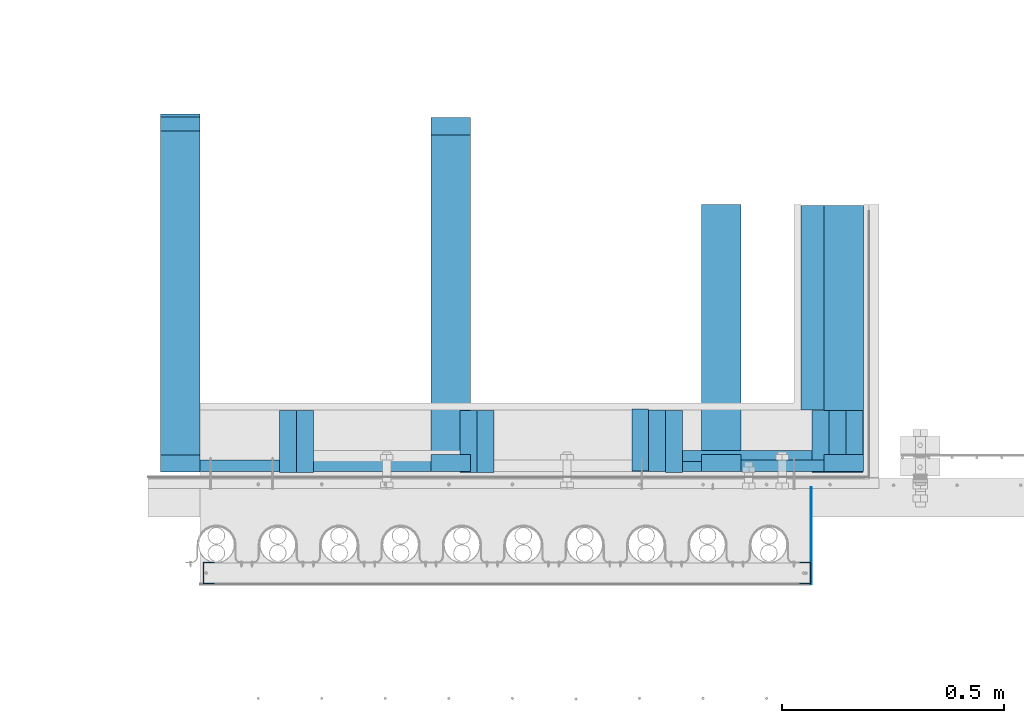
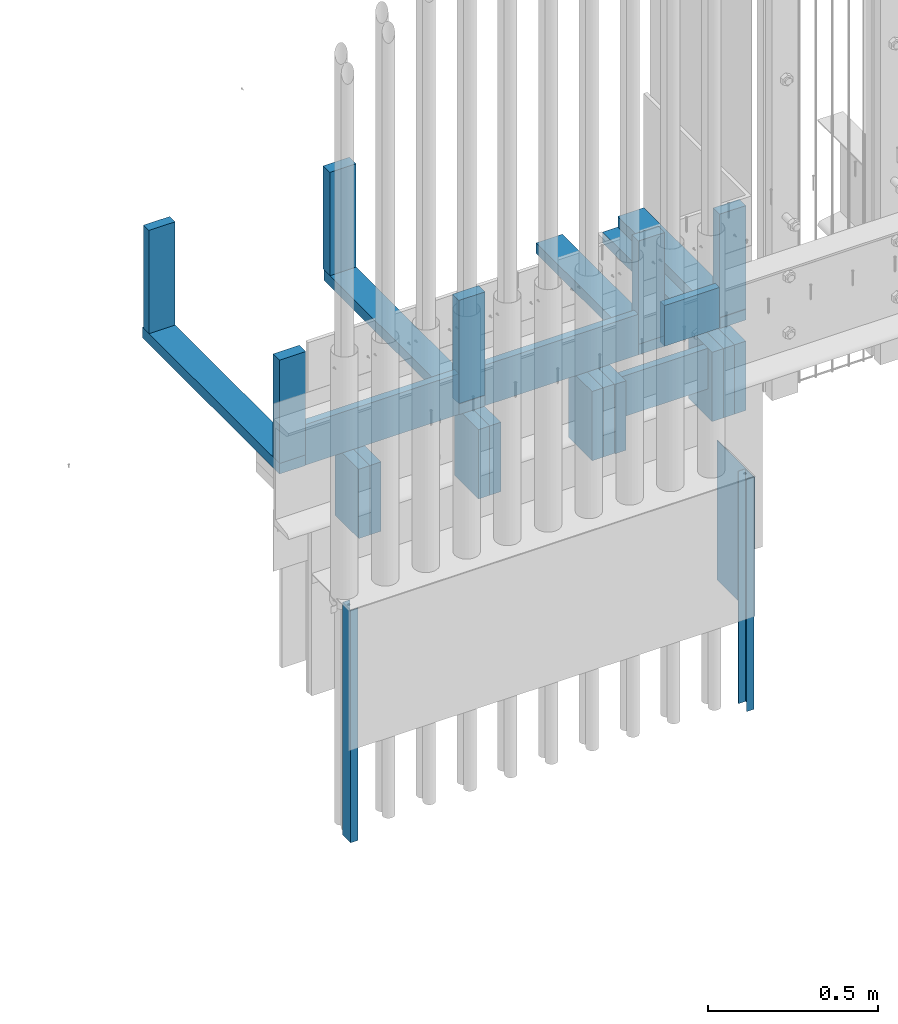
# One storey, part 2 of 44: 30 walls.
"""IFC4 building model written with IfcOpenShell, lengths in feet."""

from ifc_helpers import new_model, entity, si_unit, converted_unit, derived_unit, direction, frame, frame_2d, origin, origin_2d_with_axis, place, context, subcontext, project, spatial, polyline, rectangle, outline, extrude, material, type_object, element, save


model = new_model("IFC4")

# Units and contexts
model_context = context("Model", 3, precision=0.0001, world=origin(), true_north=direction((6.12303176911189e-17, 1.0)))
body_context = subcontext(model_context, "Body", "Model", "MODEL_VIEW")
ifc_project = project(units=[converted_unit("LENGTHUNIT", "FOOT", entity("IfcRatioMeasure", 0.3048), si_unit("LENGTHUNIT", "METRE"), dimensions=[1, 0, 0, 0, 0, 0, 0]), converted_unit("AREAUNIT", "SQUARE FOOT", entity("IfcRatioMeasure", 0.09290304), si_unit("AREAUNIT", "SQUARE_METRE"), dimensions=[2, 0, 0, 0, 0, 0, 0]), converted_unit("VOLUMEUNIT", "CUBIC FOOT", entity("IfcRatioMeasure", 0.028316846592), si_unit("VOLUMEUNIT", "CUBIC_METRE"), dimensions=[3, 0, 0, 0, 0, 0, 0]), converted_unit("PLANEANGLEUNIT", "DEGREE", entity("IfcRatioMeasure", 0.0174532925199433), si_unit("PLANEANGLEUNIT", "RADIAN"), dimensions=[0, 0, 0, 0, 0, 0, 0]), si_unit("MASSUNIT", "GRAM", prefix="KILO"), derived_unit("MASSDENSITYUNIT", [(si_unit("MASSUNIT", "GRAM", prefix="KILO"), 1), (si_unit("LENGTHUNIT", "METRE"), -3)]), derived_unit("MOMENTOFINERTIAUNIT", [(si_unit("LENGTHUNIT", "METRE"), 4)]), si_unit("TIMEUNIT", "SECOND"), si_unit("FREQUENCYUNIT", "HERTZ"), si_unit("THERMODYNAMICTEMPERATUREUNIT", "DEGREE_CELSIUS"), derived_unit("THERMALTRANSMITTANCEUNIT", [(si_unit("MASSUNIT", "GRAM", prefix="KILO"), 1), (si_unit("THERMODYNAMICTEMPERATUREUNIT", "KELVIN"), -1), (si_unit("TIMEUNIT", "SECOND"), -3)]), derived_unit("VOLUMETRICFLOWRATEUNIT", [(si_unit("LENGTHUNIT", "METRE"), 3), (si_unit("TIMEUNIT", "SECOND"), -1)]), si_unit("ELECTRICCURRENTUNIT", "AMPERE"), si_unit("ELECTRICVOLTAGEUNIT", "VOLT"), si_unit("POWERUNIT", "WATT"), si_unit("FORCEUNIT", "NEWTON"), si_unit("ILLUMINANCEUNIT", "LUX"), si_unit("LUMINOUSFLUXUNIT", "LUMEN"), si_unit("LUMINOUSINTENSITYUNIT", "CANDELA"), derived_unit("USERDEFINED", [(si_unit("MASSUNIT", "GRAM", prefix="KILO"), -1), (si_unit("LENGTHUNIT", "METRE"), -2), (si_unit("TIMEUNIT", "SECOND"), 3), (si_unit("LUMINOUSFLUXUNIT", "LUMEN"), 1)]), derived_unit("LINEARVELOCITYUNIT", [(si_unit("LENGTHUNIT", "METRE"), 1), (si_unit("TIMEUNIT", "SECOND"), -1)]), si_unit("PRESSUREUNIT", "PASCAL"), derived_unit("USERDEFINED", [(si_unit("LENGTHUNIT", "METRE"), -2), (si_unit("MASSUNIT", "GRAM", prefix="KILO"), 1), (si_unit("TIMEUNIT", "SECOND"), -2)]), derived_unit("LINEARFORCEUNIT", [(si_unit("MASSUNIT", "GRAM", prefix="KILO"), 1), (si_unit("LENGTHUNIT", "METRE"), 1), (si_unit("TIMEUNIT", "SECOND"), -2), (si_unit("LENGTHUNIT", "METRE"), -1)]), derived_unit("PLANARFORCEUNIT", [(si_unit("MASSUNIT", "GRAM", prefix="KILO"), 1), (si_unit("LENGTHUNIT", "METRE"), 1), (si_unit("TIMEUNIT", "SECOND"), -2), (si_unit("LENGTHUNIT", "METRE"), -2)])], contexts=[model_context])

# Site, building, storey
site_placement = place(None, origin())
site = spatial("IfcSite", under=ifc_project, at=site_placement, CompositionType="ELEMENT")
building_placement = place(site_placement, origin())
building = spatial("IfcBuilding", under=site, at=building_placement, CompositionType="ELEMENT")
storey_placement = place(building_placement, origin())
storey = spatial("IfcBuildingStorey", under=building, at=storey_placement, CompositionType="ELEMENT", Elevation=0.0)

# Walls
ifc_material_1 = material(Name="WOOD TRUSS - SEE STRUCT", Category="Materials")
wall_type_1 = type_object("IfcWallType", Name="Generic Models 679:Generic Models 1", PredefinedType="NOTDEFINED", material=ifc_material_1)
wall_1_placement = place(storey_placement, frame((1491.03961782017, 4.7923763016034, 9.21145047068649), z_axis=(0.0, 0.0, 1.0), x_axis=(0.0, 1.0, 0.0)))
element("IfcWall", 1, at=wall_1_placement, inside=storey, type_object=wall_type_1, material=ifc_material_1, Name="Generic Models 679:Generic Models 1", ObjectType="Generic Models 679:Generic Models 1", PredefinedType="NOTDEFINED", context=body_context, shape_type="SweptSolid", body=[
    extrude(rectangle(XDim=1.97226557063841, YDim=0.291666666666515, at=origin_2d_with_axis()), frame((0.986132785319206, -0.145833333333258, 0.0)), (0.0, 0.0, 1.0), 0.125),
])
ifc_material_2 = material(Name="(3) 2X6", Category="Materials")
wall_type_2 = type_object("IfcWallType", Name="Walls 33:Walls 13", PredefinedType="NOTDEFINED", material=ifc_material_2)
wall_2_placement = place(storey_placement, frame((1491.98232615351, 4.78471920443276, 8.14458811773391), z_axis=(0.0, 0.0, 1.0), x_axis=(0.0, 1.0, 0.0)))
element("IfcWall", 2, at=wall_2_placement, inside=storey, type_object=wall_type_2, material=ifc_material_2, Name="Walls 33:Walls 13", ObjectType="Walls 33:Walls 13", PredefinedType="NOTDEFINED", context=body_context, shape_type="SweptSolid", body=[
    extrude(rectangle(XDim=0.458333333333334, YDim=0.125, at=origin_2d_with_axis()), frame((0.229166666666667, -0.0625, 0.0)), (0.0, 0.0, 1.0), 0.816862352952286),
])
wall_type_3 = type_object("IfcWallType", Name="Walls 34:Walls 13", PredefinedType="NOTDEFINED", material=ifc_material_2)
wall_3_placement = place(storey_placement, frame((1492.10732615351, 4.78471920443276, 8.14458811773391), z_axis=(0.0, 0.0, 1.0), x_axis=(0.0, 1.0, 0.0)))
element("IfcWall", 3, at=wall_3_placement, inside=storey, type_object=wall_type_3, material=ifc_material_2, Name="Walls 34:Walls 13", ObjectType="Walls 34:Walls 13", PredefinedType="NOTDEFINED", context=body_context, shape_type="SweptSolid", body=[
    extrude(rectangle(XDim=0.458333333333334, YDim=0.125, at=origin_2d_with_axis()), frame((0.229166666666667, -0.0625, 0.0)), (0.0, 0.0, 1.0), 0.816862352952286),
])
wall_type_4 = type_object("IfcWallType", Name="Walls 35:Walls 13", PredefinedType="NOTDEFINED", material=ifc_material_2)
wall_4_placement = place(storey_placement, frame((1491.85732615351, 4.78471920443276, 8.14458811773391), z_axis=(0.0, 0.0, 1.0), x_axis=(0.0, 1.0, 0.0)))
element("IfcWall", 4, at=wall_4_placement, inside=storey, type_object=wall_type_4, material=ifc_material_2, Name="Walls 35:Walls 13", ObjectType="Walls 35:Walls 13", PredefinedType="NOTDEFINED", context=body_context, shape_type="SweptSolid", body=[
    extrude(rectangle(XDim=0.458333333333334, YDim=0.125, at=origin_2d_with_axis()), frame((0.229166666666667, -0.0625, 0.0)), (0.0, 0.0, 1.0), 0.816862352952288),
])
wall_type_5 = type_object("IfcWallType", Name="Walls 36:Walls 13", PredefinedType="NOTDEFINED", material=ifc_material_2)
wall_5_placement = place(storey_placement, frame((1490.64899282017, 4.7923763016034, 8.14458811773391), z_axis=(0.0, 0.0, 1.0), x_axis=(0.0, 1.0, 0.0)))
element("IfcWall", 5, at=wall_5_placement, inside=storey, type_object=wall_type_5, material=ifc_material_2, Name="Walls 36:Walls 13", ObjectType="Walls 36:Walls 13", PredefinedType="NOTDEFINED", context=body_context, shape_type="SweptSolid", body=[
    extrude(rectangle(XDim=0.454009569496256, YDim=0.125, at=frame_2d((4.44089209850063e-16, 0.0), x_axis=(1.0, 0.0))), frame((0.227004784748128, -0.0625, 0.0)), (0.0, 0.0, 1.0), 0.816862352952292),
])
wall_type_6 = type_object("IfcWallType", Name="Walls 37:Walls 13", PredefinedType="NOTDEFINED", material=ifc_material_2)
wall_6_placement = place(storey_placement, frame((1490.77399282017, 4.78471920443276, 8.14458811773391), z_axis=(0.0, 0.0, 1.0), x_axis=(0.0, 1.0, 0.0)))
element("IfcWall", 6, at=wall_6_placement, inside=storey, type_object=wall_type_6, material=ifc_material_2, Name="Walls 37:Walls 13", ObjectType="Walls 37:Walls 13", PredefinedType="NOTDEFINED", context=body_context, shape_type="SweptSolid", body=[
    extrude(rectangle(XDim=0.458333333333334, YDim=0.125, at=origin_2d_with_axis()), frame((0.229166666666667, -0.0625, 0.0)), (0.0, 0.0, 1.0), 0.816862352952292),
])
wall_type_7 = type_object("IfcWallType", Name="Walls 38:Walls 13", PredefinedType="NOTDEFINED", material=ifc_material_2)
wall_7_placement = place(storey_placement, frame((1490.52399282017, 4.79320370069211, 8.14458811773391), z_axis=(0.0, 0.0, 1.0), x_axis=(0.0, 1.0, 0.0)))
element("IfcWall", 7, at=wall_7_placement, inside=storey, type_object=wall_type_7, material=ifc_material_2, Name="Walls 38:Walls 13", ObjectType="Walls 38:Walls 13", PredefinedType="NOTDEFINED", context=body_context, shape_type="SweptSolid", body=[
    extrude(rectangle(XDim=0.458333333333333, YDim=0.125, at=frame_2d((8.88178419700125e-16, 0.0), x_axis=(1.0, 0.0))), frame((0.229166666666666, -0.0625, 0.0)), (0.0, 0.0, 1.0), 0.816862352952292),
])
ifc_material_3 = material(Name="(2) 2X6", Category="Materials")
wall_type_8 = type_object("IfcWallType", Name="Walls 39:Walls 13", PredefinedType="NOTDEFINED", material=ifc_material_3)
wall_8_placement = place(storey_placement, frame((1489.37815948684, 4.78471920443275, 8.14458811773391), z_axis=(0.0, 0.0, 1.0), x_axis=(0.0, 1.0, 0.0)))
element("IfcWall", 8, at=wall_8_placement, inside=storey, type_object=wall_type_8, material=ifc_material_3, Name="Walls 39:Walls 13", ObjectType="Walls 39:Walls 13", PredefinedType="NOTDEFINED", context=body_context, shape_type="SweptSolid", body=[
    extrude(rectangle(XDim=0.458333333333333, YDim=0.125, at=frame_2d((-4.44089209850063e-16, 0.0), x_axis=(1.0, 0.0))), frame((0.229166666666667, -0.0625, 0.0)), (0.0, 0.0, 1.0), 0.816862352952295),
])
wall_type_9 = type_object("IfcWallType", Name="Walls 40:Walls 13", PredefinedType="NOTDEFINED", material=ifc_material_3)
wall_9_placement = place(storey_placement, frame((1489.25315948684, 4.78471920443275, 8.14458811773391), z_axis=(0.0, 0.0, 1.0), x_axis=(0.0, 1.0, 0.0)))
element("IfcWall", 9, at=wall_9_placement, inside=storey, type_object=wall_type_9, material=ifc_material_3, Name="Walls 40:Walls 13", ObjectType="Walls 40:Walls 13", PredefinedType="NOTDEFINED", context=body_context, shape_type="SweptSolid", body=[
    extrude(rectangle(XDim=0.458333333333333, YDim=0.125, at=frame_2d((-4.44089209850063e-16, 0.0), x_axis=(1.0, 0.0))), frame((0.229166666666667, -0.0625, 0.0)), (0.0, 0.0, 1.0), 0.816862352952295),
])
wall_type_10 = type_object("IfcWallType", Name="Walls 41:Walls 13", PredefinedType="NOTDEFINED", material=ifc_material_3)
wall_10_placement = place(storey_placement, frame((1488.04482615351, 4.78471920443275, 8.14458811773391), z_axis=(0.0, 0.0, 1.0), x_axis=(0.0, 1.0, 0.0)))
element("IfcWall", 10, at=wall_10_placement, inside=storey, type_object=wall_type_10, material=ifc_material_3, Name="Walls 41:Walls 13", ObjectType="Walls 41:Walls 13", PredefinedType="NOTDEFINED", context=body_context, shape_type="SweptSolid", body=[
    extrude(rectangle(XDim=0.458333333333334, YDim=0.125, at=origin_2d_with_axis()), frame((0.229166666666667, -0.0625, 0.0)), (0.0, 0.0, 1.0), 0.816862352952299),
])
wall_type_11 = type_object("IfcWallType", Name="Walls 42:Walls 13", PredefinedType="NOTDEFINED", material=ifc_material_3)
wall_11_placement = place(storey_placement, frame((1487.91982615351, 4.78471920443275, 8.14458811773391), z_axis=(0.0, 0.0, 1.0), x_axis=(0.0, 1.0, 0.0)))
element("IfcWall", 11, at=wall_11_placement, inside=storey, type_object=wall_type_11, material=ifc_material_3, Name="Walls 42:Walls 13", ObjectType="Walls 42:Walls 13", PredefinedType="NOTDEFINED", context=body_context, shape_type="SweptSolid", body=[
    extrude(rectangle(XDim=0.458333333333333, YDim=0.125, at=frame_2d((4.44089209850063e-16, 0.0), x_axis=(1.0, 0.0))), frame((0.229166666666666, -0.0625, 0.0)), (0.0, 0.0, 1.0), 0.816862352952299),
])
ifc_material_4 = material(Name="BLOCKING TYP - SEE STRUCTURAL", Category="Materials")
wall_type_12 = type_object("IfcWallType", Name="Generic Models 665:Generic Models 1", PredefinedType="NOTDEFINED", material=ifc_material_4)
wall_12_placement = place(storey_placement, frame((1490.89899282017, 4.86354134091661, 8.48228380401073)))
element("IfcWall", 12, at=wall_12_placement, inside=storey, type_object=wall_type_12, material=ifc_material_4, Name="Generic Models 665:Generic Models 1", ObjectType="Generic Models 665:Generic Models 1", PredefinedType="NOTDEFINED", context=body_context, shape_type="SweptSolid", body=[
    extrude(rectangle(XDim=0.083333333333333, YDim=0.958333333333258, at=frame_2d((-4.44089209850063e-16, -1.13686837721616e-13), x_axis=(1.0, 0.0))), frame((0.479166666666515, 0.0416666666666696, 0.0), z_axis=(0.0, 0.0, 1.0), x_axis=(0.0, 1.0, 0.0)), (0.0, 0.0, 1.0), 0.479166666675471),
])
ifc_material_5 = material(Name="BLOCKING TYP", Category="Materials")
wall_type_13 = type_object("IfcWallType", Name="Generic Models 742:Generic Models 1", PredefinedType="NOTDEFINED", material=ifc_material_5)
wall_13_placement = place(storey_placement, frame((1489.33128448684, 4.79201248172416, 9.21145047068651)))
element("IfcWall", 13, at=wall_13_placement, inside=storey, type_object=wall_type_13, material=ifc_material_5, Name="Generic Models 742:Generic Models 1", ObjectType="Generic Models 742:Generic Models 1", PredefinedType="NOTDEFINED", context=body_context, shape_type="SweptSolid", body=[
    extrude(rectangle(XDim=0.0833333333333339, YDim=1.70833333333326, at=frame_2d((0.0, 1.13686837721616e-13), x_axis=(1.0, 0.0))), frame((0.854166666666742, 0.0416666666666714, 0.0), z_axis=(0.0, 0.0, 1.0), x_axis=(0.0, 1.0, 0.0)), (0.0, 0.0, 1.0), 0.479166666675475),
])
wall_type_14 = type_object("IfcWallType", Name="Generic Models 744:Generic Models 1", PredefinedType="NOTDEFINED", material=ifc_material_1)
wall_14_placement = place(storey_placement, frame((1489.03961782017, 4.7923763016034, 9.3364504706865)))
element("IfcWall", 14, at=wall_14_placement, inside=storey, type_object=wall_type_14, material=ifc_material_1, Name="Generic Models 744:Generic Models 1", ObjectType="Generic Models 744:Generic Models 1", PredefinedType="NOTDEFINED", context=body_context, shape_type="SweptSolid", body=[
    extrude(rectangle(XDim=0.125000000000002, YDim=0.291666666666742, at=frame_2d((4.44089209850063e-16, 0.0), x_axis=(1.0, 0.0))), frame((0.145833333333485, 0.0625000000000009, 0.0), z_axis=(0.0, 0.0, 1.0), x_axis=(0.0, 1.0, 0.0)), (0.0, 0.0, 1.0), 1.21681372913856),
])
wall_type_15 = type_object("IfcWallType", Name="Generic Models 745:Generic Models 1", PredefinedType="NOTDEFINED", material=ifc_material_1)
wall_15_placement = place(storey_placement, frame((1487.03961782017, 4.78805253776631, 9.3364504706865)))
element("IfcWall", 15, at=wall_15_placement, inside=storey, type_object=wall_type_15, material=ifc_material_1, Name="Generic Models 745:Generic Models 1", ObjectType="Generic Models 745:Generic Models 1", PredefinedType="NOTDEFINED", context=body_context, shape_type="SweptSolid", body=[
    extrude(rectangle(XDim=0.125000000000002, YDim=0.291666666666742, at=frame_2d((4.44089209850063e-16, 0.0), x_axis=(1.0, 0.0))), frame((0.145833333333485, 0.0625000000000009, 0.0), z_axis=(0.0, 0.0, 1.0), x_axis=(0.0, 1.0, 0.0)), (0.0, 0.0, 1.0), 1.21606420821603),
])
wall_type_16 = type_object("IfcWallType", Name="Generic Models 748:Generic Models 1", PredefinedType="NOTDEFINED", material=ifc_material_1)
wall_16_placement = place(storey_placement, frame((1487.03961782017, 7.30888587109964, 9.33645047068652)))
element("IfcWall", 16, at=wall_16_placement, inside=storey, type_object=wall_type_16, material=ifc_material_1, Name="Generic Models 748:Generic Models 1", ObjectType="Generic Models 748:Generic Models 1", PredefinedType="NOTDEFINED", context=body_context, shape_type="SweptSolid", body=[
    extrude(rectangle(XDim=0.104166666666666, YDim=0.291666666666742, at=frame_2d((-4.44089209850063e-16, 0.0), x_axis=(1.0, 0.0))), frame((0.145833333333485, 0.0520833333333339, 0.0), z_axis=(0.0, 0.0, 1.0), x_axis=(0.0, 1.0, 0.0)), (0.0, 0.0, 1.0), 1.21606420821603),
])
wall_type_17 = type_object("IfcWallType", Name="Generic Models 738:Generic Models 1", PredefinedType="NOTDEFINED", material=ifc_material_1)
wall_17_placement = place(storey_placement, frame((1491.94456573684, 4.78471920443274, 9.2114504706865), z_axis=(0.0, 0.0, 1.0), x_axis=(0.0, 1.0, 0.0)))
element("IfcWall", 17, at=wall_17_placement, inside=storey, type_object=wall_type_17, material=ifc_material_1, Name="Generic Models 738:Generic Models 1", ObjectType="Generic Models 738:Generic Models 1", PredefinedType="NOTDEFINED", context=body_context, shape_type="SweptSolid", body=[
    extrude(rectangle(XDim=1.97226557063841, YDim=0.291666666666515, at=frame_2d((-4.44089209850063e-16, 0.0), x_axis=(1.0, 0.0))), frame((0.986132785319206, -0.145833333333258, 0.0)), (0.0, 0.0, 1.0), 0.125),
])
wall_type_18 = type_object("IfcWallType", Name="Generic Models 750:Generic Models 1", PredefinedType="NOTDEFINED", material=ifc_material_4)
wall_18_placement = place(storey_placement, frame((1491.33128448684, 4.7923763016034, 9.21145047068651)))
element("IfcWall", 18, at=wall_18_placement, inside=storey, type_object=wall_type_18, material=ifc_material_4, Name="Generic Models 750:Generic Models 1", ObjectType="Generic Models 750:Generic Models 1", PredefinedType="NOTDEFINED", context=body_context, shape_type="SweptSolid", body=[
    extrude(rectangle(XDim=0.083333333333333, YDim=0.613281250000227, at=frame_2d((0.0, 1.13686837721616e-13), x_axis=(1.0, 0.0))), frame((0.306640625000227, 0.0416666666666687, 0.0), z_axis=(0.0, 0.0, 1.0), x_axis=(0.0, 1.0, 0.0)), (0.0, 0.0, 1.0), 0.479166666675475),
])
wall_type_19 = type_object("IfcWallType", Name="Generic Models 746:Generic Models 1", PredefinedType="NOTDEFINED", material=ifc_material_1)
wall_19_placement = place(storey_placement, frame((1489.03961782017, 4.7880525377663, 9.21145047068649), z_axis=(0.0, 0.0, 1.0), x_axis=(0.0, 1.0, 0.0)))
element("IfcWall", 19, at=wall_19_placement, inside=storey, type_object=wall_type_19, material=ifc_material_1, Name="Generic Models 746:Generic Models 1", ObjectType="Generic Models 746:Generic Models 1", PredefinedType="NOTDEFINED", context=body_context, shape_type="SweptSolid", body=[
    extrude(rectangle(XDim=2.60416666666667, YDim=0.291666666666515, at=frame_2d((4.44089209850063e-16, 0.0), x_axis=(1.0, 0.0))), frame((1.30208333333333, -0.145833333333258, 0.0)), (0.0, 0.0, 1.0), 0.124999999999998),
])
wall_type_20 = type_object("IfcWallType", Name="Generic Models 757:Generic Models 1", PredefinedType="NOTDEFINED", material=ifc_material_1)
wall_20_placement = place(storey_placement, frame((1487.03961782017, 4.78805253776631, 9.21145047068649), z_axis=(0.0, 0.0, 1.0), x_axis=(0.0, 1.0, 0.0)))
element("IfcWall", 20, at=wall_20_placement, inside=storey, type_object=wall_type_20, material=ifc_material_1, Name="Generic Models 757:Generic Models 1", ObjectType="Generic Models 757:Generic Models 1", PredefinedType="NOTDEFINED", context=body_context, shape_type="SweptSolid", body=[
    extrude(rectangle(XDim=2.64583333333333, YDim=0.291666666666515, at=origin_2d_with_axis()), frame((1.32291666666667, -0.145833333333258, 0.0)), (0.0, 0.0, 1.0), 0.124999999999998),
])
wall_type_21 = type_object("IfcWallType", Name="Generic Models 760:Generic Models 1", PredefinedType="NOTDEFINED", material=ifc_material_5)
wall_21_placement = place(storey_placement, frame((1487.33128448684, 4.79237630160339, 9.2114504706865)))
element("IfcWall", 21, at=wall_21_placement, inside=storey, type_object=wall_type_21, material=ifc_material_5, Name="Generic Models 760:Generic Models 1", ObjectType="Generic Models 760:Generic Models 1", PredefinedType="NOTDEFINED", context=body_context, shape_type="SweptSolid", body=[
    extrude(rectangle(XDim=0.0833333333333339, YDim=1.70833333333326, at=frame_2d((0.0, 1.13686837721616e-13), x_axis=(1.0, 0.0))), frame((0.854166666666742, 0.0416666666666714, 0.0), z_axis=(0.0, 0.0, 1.0), x_axis=(0.0, 1.0, 0.0)), (0.0, 0.0, 1.0), 0.479166666675475),
])
wall_type_22 = type_object("IfcWallType", Name="Generic Models 765:Generic Models 1", PredefinedType="NOTDEFINED", material=ifc_material_1)
wall_22_placement = place(storey_placement, frame((1491.03961782017, 4.7923763016034, 9.33645047068649)))
element("IfcWall", 22, at=wall_22_placement, inside=storey, type_object=wall_type_22, material=ifc_material_1, Name="Generic Models 765:Generic Models 1", ObjectType="Generic Models 765:Generic Models 1", PredefinedType="NOTDEFINED", context=body_context, shape_type="SweptSolid", body=[
    extrude(rectangle(XDim=0.125000000000002, YDim=0.291666666666742, at=frame_2d((-4.44089209850063e-16, 0.0), x_axis=(1.0, 0.0))), frame((0.145833333333485, 0.0625000000000018, 0.0), z_axis=(0.0, 0.0, 1.0), x_axis=(0.0, 1.0, 0.0)), (0.0, 0.0, 1.0), 1.21574457292019),
])
wall_type_23 = type_object("IfcWallType", Name="Generic Models 766:Generic Models 1", PredefinedType="NOTDEFINED", material=ifc_material_1)
wall_23_placement = place(storey_placement, frame((1489.03961782017, 4.7923763016034, 9.3364504706865)))
element("IfcWall", 23, at=wall_23_placement, inside=storey, type_object=wall_type_23, material=ifc_material_1, Name="Generic Models 766:Generic Models 1", ObjectType="Generic Models 766:Generic Models 1", PredefinedType="NOTDEFINED", context=body_context, shape_type="SweptSolid", body=[
    extrude(rectangle(XDim=0.125000000000002, YDim=0.291666666666742, at=frame_2d((4.44089209850063e-16, 0.0), x_axis=(1.0, 0.0))), frame((0.145833333333485, 0.0625000000000009, 0.0), z_axis=(0.0, 0.0, 1.0), x_axis=(0.0, 1.0, 0.0)), (0.0, 0.0, 1.0), 1.21681372913856),
])
wall_type_24 = type_object("IfcWallType", Name="Generic Models 771:Generic Models 1", PredefinedType="NOTDEFINED", material=ifc_material_1)
wall_24_placement = place(storey_placement, frame((1491.94456573684, 4.79237630160339, 9.33645047068649)))
element("IfcWall", 24, at=wall_24_placement, inside=storey, type_object=wall_type_24, material=ifc_material_1, Name="Generic Models 771:Generic Models 1", ObjectType="Generic Models 771:Generic Models 1", PredefinedType="NOTDEFINED", context=body_context, shape_type="SweptSolid", body=[
    extrude(rectangle(XDim=0.125000000000002, YDim=0.291666666666742, at=frame_2d((4.44089209850063e-16, 2.27373675443232e-13), x_axis=(1.0, 0.0))), frame((0.145833333333712, 0.0625000000000009, 0.0), z_axis=(0.0, 0.0, 1.0), x_axis=(0.0, 1.0, 0.0)), (0.0, 0.0, 1.0), 1.21574457292019),
])
wall_type_25 = type_object("IfcWallType", Name="Generic Models 772:Generic Models 1", PredefinedType="NOTDEFINED", material=ifc_material_4)
wall_25_placement = place(storey_placement, frame((1491.33128448684, 4.7923763016034, 9.21145047068651)))
element("IfcWall", 25, at=wall_25_placement, inside=storey, type_object=wall_type_25, material=ifc_material_4, Name="Generic Models 772:Generic Models 1", ObjectType="Generic Models 772:Generic Models 1", PredefinedType="NOTDEFINED", context=body_context, shape_type="SweptSolid", body=[
    extrude(rectangle(XDim=0.083333333333333, YDim=0.613281250000227, at=frame_2d((0.0, 1.13686837721616e-13), x_axis=(1.0, 0.0))), frame((0.306640625000227, 0.0416666666666687, 0.0), z_axis=(0.0, 0.0, 1.0), x_axis=(0.0, 1.0, 0.0)), (0.0, 0.0, 1.0), 0.479166666675475),
])
ifc_material_6 = material(Name="2X10 JOISTS", Category="Materials")
wall_type_26 = type_object("IfcWallType", Name="Walls 48:Walls 13", PredefinedType="NOTDEFINED", material=ifc_material_6)
wall_26_placement = place(storey_placement, frame((1491.77399282017, 5.24638587109967, 9.08645047068623), z_axis=(0.0, 0.0, 1.0), x_axis=(0.0, 1.0, 0.0)))
element("IfcWall", 26, at=wall_26_placement, inside=storey, type_object=wall_type_26, material=ifc_material_6, Name="Walls 48:Walls 13", ObjectType="Walls 48:Walls 13", PredefinedType="NOTDEFINED", context=body_context, shape_type="SweptSolid", body=[
    extrude(rectangle(XDim=1.51059890397147, YDim=0.458333333333258, at=frame_2d((-4.44089209850063e-16, -1.13686837721616e-13), x_axis=(1.0, 0.0))), frame((0.755299451985736, -0.229166666666515, 0.0)), (0.0, 0.0, 1.0), 0.125000000000004),
])
wall_type_27 = type_object("IfcWallType", Name="Generic Models 635:Generic Models 1", PredefinedType="NOTDEFINED", material=ifc_material_1)
wall_27_placement = place(storey_placement, frame((1489.03961782017, 7.28071946107701, 9.33645047068651)))
element("IfcWall", 27, at=wall_27_placement, inside=storey, type_object=wall_type_27, material=ifc_material_1, Name="Generic Models 635:Generic Models 1", ObjectType="Generic Models 635:Generic Models 1", PredefinedType="NOTDEFINED", context=body_context, shape_type="SweptSolid", body=[
    extrude(rectangle(XDim=0.128333333333559, YDim=0.291666666666515, at=frame_2d((4.44089209850063e-16, -2.27373675443232e-13), x_axis=(1.0, 0.0))), frame((0.14583333333303, 0.0641666666667797, 0.0), z_axis=(0.0, 0.0, 1.0), x_axis=(0.0, 1.0, 0.0)), (0.0, 0.0, 1.0), 1.21681372913856),
])
ifc_material_7 = material(Category="Materials")
wall_type_28 = type_object("IfcWallType", Name="Metal stud4:Metal stud", PredefinedType="NOTDEFINED", material=ifc_material_7)
wall_28_placement = place(storey_placement, frame((1491.76423162332, 3.95990893651113, 5.26036370303952), z_axis=(0.0, 0.0, 1.0), x_axis=(0.0, 1.0, 0.0)))
element("IfcWall", 28, at=wall_28_placement, inside=storey, type_object=wall_type_28, material=ifc_material_7, Name="Metal stud4:Metal stud", ObjectType="Metal stud4:Metal stud", PredefinedType="NOTDEFINED", context=body_context, shape_type="SweptSolid", body=[
    extrude(outline(polyline([(-0.04296875, -0.0807291666667043), (0.0403645833334849, -0.0807291666667043), (0.0403645833334849, -0.0755208333333712), (-0.0377604166667425, -0.0755208333333712), (-0.0377604166667425, 0.0755208333334476), (0.0403645833334849, 0.0755208333334476), (0.0403645833334849, 0.0807291666666297), (-0.04296875, 0.0807291666666297), (-0.04296875, -0.0807291666667043)])), frame((0.0807291666666292, -0.0403645833334849, 0.0), z_axis=(0.0, 0.0, 1.0), x_axis=(0.0, 1.0, 0.0)), (0.0, 0.0, 1.0), 2.73764420223197),
])
wall_type_29 = type_object("IfcWallType", Name="Metal stud6:Metal stud", PredefinedType="NOTDEFINED", material=ifc_material_7)
wall_29_placement = place(storey_placement, frame((1487.35364577433, 3.95990893651115, 5.26036370303926), z_axis=(0.0, 0.0, 1.0), x_axis=(0.0, 1.0, 0.0)))
element("IfcWall", 29, at=wall_29_placement, inside=storey, type_object=wall_type_29, material=ifc_material_7, Name="Metal stud6:Metal stud", ObjectType="Metal stud6:Metal stud", PredefinedType="NOTDEFINED", context=body_context, shape_type="SweptSolid", body=[
    extrude(outline(polyline([(-0.0429687499999996, -0.0807291666667045), (0.0403645833334853, -0.0807291666667045), (0.0403645833334853, -0.0755208333333715), (-0.0377604166667421, -0.0755208333333714), (-0.0377604166667429, 0.0755208333334474), (0.0403645833334845, 0.0755208333334478), (0.0403645833334845, 0.0807291666666299), (-0.0429687500000004, 0.0807291666666294), (-0.0429687499999996, -0.0807291666667045)])), frame((0.080729166666706, -0.0429687500004547, 0.0), z_axis=(0.0, 0.0, 1.0), x_axis=(0.0, -1.0, 0.0)), (0.0, 0.0, 1.0), 2.73764420222472),
])
ifc_material_8 = material(Name="16 GA. PERFORATED GALV. STEEL PANEL", Category="Materials")
wall_type_30 = type_object("IfcWallType", Name="PERFORATED GALV. STEEL PANEL2:PERFORATED GALV. STEEL PANEL", PredefinedType="NOTDEFINED", material=ifc_material_8)
wall_30_placement = place(storey_placement, frame((1491.84756495666, 3.9562694627104, 6.35379761447848), z_axis=(0.0, 0.0, 1.0), x_axis=(0.0, 1.0, 0.0)))
element("IfcWall", 30, at=wall_30_placement, inside=storey, type_object=wall_type_30, material=ifc_material_8, Name="PERFORATED GALV. STEEL PANEL2:PERFORATED GALV. STEEL PANEL", ObjectType="PERFORATED GALV. STEEL PANEL2:PERFORATED GALV. STEEL PANEL", PredefinedType="NOTDEFINED", context=body_context, shape_type="SweptSolid", body=[
    extrude(rectangle(XDim=0.717199741722671, YDim=0.0052499999999327, at=frame_2d((-4.44089209850063e-16, 1.13686837721616e-13), x_axis=(1.0, 0.0))), frame((0.358599870861335, -0.00262499999985266, 0.0), z_axis=(0.0, 0.0, 1.0), x_axis=(-1.0, 0.0, 0.0)), (0.0, 0.0, 1.0), 1.64421029078539),
])

save(model, "model.ifc")
